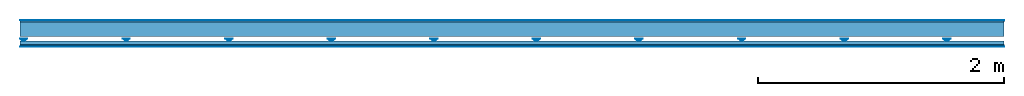
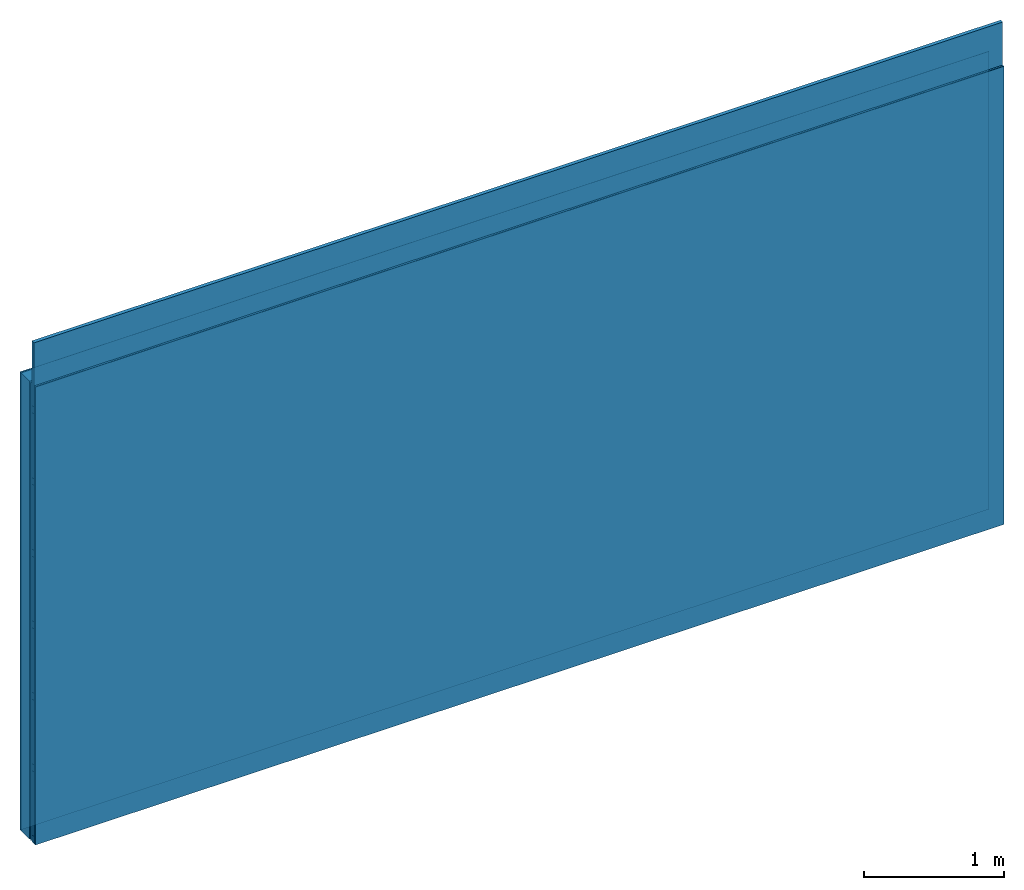
# One storey: 4 members, 4 plates, 1 element without a shape of its own.
"""IFC4 building model written with IfcOpenShell, lengths in metres."""

from ifc_helpers import new_model, si_unit, derived_unit, direction, frame, frame_2d, origin, origin_with_axes, place, context, project, spatial, polyline, rectangle, outline, extrude, material, layer, layer_set, type_object, element, aggregate, save


model = new_model("IFC4")

# Units and contexts
plan_context = context("Plan", 3, precision=1e-05, world=origin(), true_north=direction((0.0, 1.0)))
model_context = context("Model", 3, precision=1e-05, world=origin(), true_north=direction((0.0, 1.0)))
ifc_project = project(units=[si_unit("LENGTHUNIT", "METRE"), derived_unit("SOUNDPRESSUREUNIT", [(si_unit("PRESSUREUNIT", "PASCAL", prefix="MICRO"), 0)]), si_unit("ENERGYUNIT", "JOULE", prefix="MEGA"), si_unit("MASSUNIT", "GRAM", prefix="KILO"), derived_unit("THERMALTRANSMITTANCEUNIT", [(si_unit("POWERUNIT", "WATT"), 1), (si_unit("AREAUNIT", "SQUARE_METRE"), -1), (si_unit("THERMODYNAMICTEMPERATUREUNIT", "KELVIN"), -1)]), derived_unit("AREADENSITYUNIT", [(si_unit("MASSUNIT", "GRAM", prefix="KILO"), 1), (si_unit("AREAUNIT", "SQUARE_METRE"), -1)]), derived_unit("USERDEFINED", [(si_unit("ENERGYUNIT", "JOULE", prefix="MEGA"), 1), (si_unit("AREAUNIT", "SQUARE_METRE"), -1)])], contexts=[plan_context, model_context])

# Site, building, storey
site = spatial("IfcSite", under=ifc_project)
building_placement = place(None, origin())
building = spatial("IfcBuilding", under=site, at=building_placement)
storey_placement = place(building_placement, origin())
storey = spatial("IfcBuildingStorey", under=building, at=storey_placement)

# Wall, members, plates
ifc_material_1 = material(Category="04.001")
ifc_layer_1 = layer(ifc_material_1, 0.003, Name="Surface")
ifc_material_2 = material(Name="Plasterboard type A", Category="03.008")
ifc_layer_2 = layer(ifc_material_2, 0.0125, Name="1st layer")
ifc_material_3 = material(Name="of the art")
ifc_layer_3 = layer(ifc_material_3, 0.0, Name="Bond")
ifc_layer_4 = layer(None, 0.12, Name="Support")
ifc_layer_5 = layer(None, 0.036, Name="Coupling")
ifc_layer_6 = layer(None, 0.03, Name="Battens / profiles")
ifc_material_4 = material(Name="DFH2IR Knauf Diamant hard- plasterboard", Category="03.007")
ifc_layer_7 = layer(ifc_material_4, 0.015, Name="Covering 1st layer")
ifc_layer_8 = layer(ifc_material_1, 0.003, Name="Surface")
ifc_layer_set = layer_set([ifc_layer_1, ifc_layer_2, ifc_layer_3, ifc_layer_4, ifc_layer_5, ifc_layer_6, ifc_layer_7, ifc_layer_8])
wall_type = type_object("IfcWallType", Name="C0377", PredefinedType="NOTDEFINED", material=ifc_layer_set)
wall_placement = place(None, frame((0.0, 0.0, 0.0), z_axis=(0.0, -1.0, 0.0), x_axis=(1.0, 0.0, 0.0)))
wall = element("IfcWall", 1, at=wall_placement, inside=storey, type_object=wall_type, material=ifc_layer_set, Name="Wall #1")
ifc_material_5 = material(Name="Solid timber panel")
member_1_placement = place(wall_placement, origin())
member_1 = element("IfcMember", 2, at=member_1_placement, material=ifc_material_5, Name="Support", context=plan_context, shape_type="SweptSolid", body=[
    extrude(rectangle(XDim=1.0, YDim=0.12, at=frame_2d((0.5, 0.06), x_axis=(1.0, 0.0))), frame((0.0, 4.0, 0.0155), z_axis=(0.0, -1.0, 0.0), x_axis=(1.0, 0.0, 0.0)), (0.0, 0.0, 1.0), 4.0),
    extrude(rectangle(XDim=1.0, YDim=0.12, at=frame_2d((0.5, 0.06), x_axis=(1.0, 0.0))), frame((1.0, 4.0, 0.0155), z_axis=(0.0, -1.0, 0.0), x_axis=(1.0, 0.0, 0.0)), (0.0, 0.0, 1.0), 4.0),
    extrude(rectangle(XDim=1.0, YDim=0.12, at=frame_2d((0.5, 0.06), x_axis=(1.0, 0.0))), frame((2.0, 4.0, 0.0155), z_axis=(0.0, -1.0, 0.0), x_axis=(1.0, 0.0, 0.0)), (0.0, 0.0, 1.0), 4.0),
    extrude(rectangle(XDim=1.0, YDim=0.12, at=frame_2d((0.5, 0.06), x_axis=(1.0, 0.0))), frame((3.0, 4.0, 0.0155), z_axis=(0.0, -1.0, 0.0), x_axis=(1.0, 0.0, 0.0)), (0.0, 0.0, 1.0), 4.0),
    extrude(rectangle(XDim=1.0, YDim=0.12, at=frame_2d((0.5, 0.06), x_axis=(1.0, 0.0))), frame((4.0, 4.0, 0.0155), z_axis=(0.0, -1.0, 0.0), x_axis=(1.0, 0.0, 0.0)), (0.0, 0.0, 1.0), 4.0),
    extrude(rectangle(XDim=1.0, YDim=0.12, at=frame_2d((0.5, 0.06), x_axis=(1.0, 0.0))), frame((5.0, 4.0, 0.0155), z_axis=(0.0, -1.0, 0.0), x_axis=(1.0, 0.0, 0.0)), (0.0, 0.0, 1.0), 4.0),
    extrude(rectangle(XDim=1.0, YDim=0.12, at=frame_2d((0.5, 0.06), x_axis=(1.0, 0.0))), frame((6.0, 4.0, 0.0155), z_axis=(0.0, -1.0, 0.0), x_axis=(1.0, 0.0, 0.0)), (0.0, 0.0, 1.0), 4.0),
    extrude(rectangle(XDim=1.0, YDim=0.12, at=frame_2d((0.5, 0.06), x_axis=(1.0, 0.0))), frame((7.0, 4.0, 0.0155), z_axis=(0.0, -1.0, 0.0), x_axis=(1.0, 0.0, 0.0)), (0.0, 0.0, 1.0), 4.0),
])
ifc_material_6 = material()
member_2_placement = place(wall_placement, origin())
member_2 = element("IfcMember", 3, at=member_2_placement, material=ifc_material_6, Name="Coupling", context=plan_context, shape_type="SweptSolid", body=[
    extrude(outline(polyline([(0.0, 0.0), (0.06, 0.0), (0.04, 0.02), (0.02, 0.02), (0.0, 0.0)])), frame((0.0, 4.0, 0.1515), z_axis=(0.0, -1.0, 0.0), x_axis=(1.0, 0.0, 0.0)), (0.0, 0.0, 1.0), 4.0),
    extrude(outline(polyline([(0.0, 0.0), (0.06, 0.0), (0.04, 0.02), (0.02, 0.02), (0.0, 0.0)])), frame((0.834, 4.0, 0.1515), z_axis=(0.0, -1.0, 0.0), x_axis=(1.0, 0.0, 0.0)), (0.0, 0.0, 1.0), 4.0),
    extrude(outline(polyline([(0.0, 0.0), (0.06, 0.0), (0.04, 0.02), (0.02, 0.02), (0.0, 0.0)])), frame((1.668, 4.0, 0.1515), z_axis=(0.0, -1.0, 0.0), x_axis=(1.0, 0.0, 0.0)), (0.0, 0.0, 1.0), 4.0),
    extrude(outline(polyline([(0.0, 0.0), (0.06, 0.0), (0.04, 0.02), (0.02, 0.02), (0.0, 0.0)])), frame((2.502, 4.0, 0.1515), z_axis=(0.0, -1.0, 0.0), x_axis=(1.0, 0.0, 0.0)), (0.0, 0.0, 1.0), 4.0),
    extrude(outline(polyline([(0.0, 0.0), (0.06, 0.0), (0.04, 0.02), (0.02, 0.02), (0.0, 0.0)])), frame((3.336, 4.0, 0.1515), z_axis=(0.0, -1.0, 0.0), x_axis=(1.0, 0.0, 0.0)), (0.0, 0.0, 1.0), 4.0),
    extrude(outline(polyline([(0.0, 0.0), (0.06, 0.0), (0.04, 0.02), (0.02, 0.02), (0.0, 0.0)])), frame((4.17, 4.0, 0.1515), z_axis=(0.0, -1.0, 0.0), x_axis=(1.0, 0.0, 0.0)), (0.0, 0.0, 1.0), 4.0),
    extrude(outline(polyline([(0.0, 0.0), (0.06, 0.0), (0.04, 0.02), (0.02, 0.02), (0.0, 0.0)])), frame((5.004, 4.0, 0.1515), z_axis=(0.0, -1.0, 0.0), x_axis=(1.0, 0.0, 0.0)), (0.0, 0.0, 1.0), 4.0),
    extrude(outline(polyline([(0.0, 0.0), (0.06, 0.0), (0.04, 0.02), (0.02, 0.02), (0.0, 0.0)])), frame((5.838, 4.0, 0.1515), z_axis=(0.0, -1.0, 0.0), x_axis=(1.0, 0.0, 0.0)), (0.0, 0.0, 1.0), 4.0),
    extrude(outline(polyline([(0.0, 0.0), (0.06, 0.0), (0.04, 0.02), (0.02, 0.02), (0.0, 0.0)])), frame((6.672, 4.0, 0.1515), z_axis=(0.0, -1.0, 0.0), x_axis=(1.0, 0.0, 0.0)), (0.0, 0.0, 1.0), 4.0),
    extrude(outline(polyline([(0.0, 0.0), (0.06, 0.0), (0.04, 0.02), (0.02, 0.02), (0.0, 0.0)])), frame((7.506, 4.0, 0.1515), z_axis=(0.0, -1.0, 0.0), x_axis=(1.0, 0.0, 0.0)), (0.0, 0.0, 1.0), 4.0),
])
member_3_placement = place(wall_placement, origin())
member_3 = element("IfcMember", 4, at=member_3_placement, material=ifc_material_6, Name="Battens / profiles", context=plan_context, shape_type="SweptSolid", body=[
    extrude(rectangle(XDim=0.06, YDim=0.03, at=frame_2d((0.03, 0.015), x_axis=(1.0, 0.0))), frame((0.0, 0.0, 0.1715), z_axis=(1.0, 0.0, 0.0), x_axis=(0.0, 1.0, 0.0)), (0.0, 0.0, 1.0), 8.0),
    extrude(rectangle(XDim=0.06, YDim=0.03, at=frame_2d((0.03, 0.015), x_axis=(1.0, 0.0))), frame((0.0, 0.625, 0.1715), z_axis=(1.0, 0.0, 0.0), x_axis=(0.0, 1.0, 0.0)), (0.0, 0.0, 1.0), 8.0),
    extrude(rectangle(XDim=0.06, YDim=0.03, at=frame_2d((0.03, 0.015), x_axis=(1.0, 0.0))), frame((0.0, 1.25, 0.1715), z_axis=(1.0, 0.0, 0.0), x_axis=(0.0, 1.0, 0.0)), (0.0, 0.0, 1.0), 8.0),
    extrude(rectangle(XDim=0.06, YDim=0.03, at=frame_2d((0.03, 0.015), x_axis=(1.0, 0.0))), frame((0.0, 1.875, 0.1715), z_axis=(1.0, 0.0, 0.0), x_axis=(0.0, 1.0, 0.0)), (0.0, 0.0, 1.0), 8.0),
    extrude(rectangle(XDim=0.06, YDim=0.03, at=frame_2d((0.03, 0.015), x_axis=(1.0, 0.0))), frame((0.0, 2.5, 0.1715), z_axis=(1.0, 0.0, 0.0), x_axis=(0.0, 1.0, 0.0)), (0.0, 0.0, 1.0), 8.0),
    extrude(rectangle(XDim=0.06, YDim=0.03, at=frame_2d((0.03, 0.015), x_axis=(1.0, 0.0))), frame((0.0, 3.125, 0.1715), z_axis=(1.0, 0.0, 0.0), x_axis=(0.0, 1.0, 0.0)), (0.0, 0.0, 1.0), 8.0),
    extrude(rectangle(XDim=0.06, YDim=0.03, at=frame_2d((0.03, 0.015), x_axis=(1.0, 0.0))), frame((0.0, 3.75, 0.1715), z_axis=(1.0, 0.0, 0.0), x_axis=(0.0, 1.0, 0.0)), (0.0, 0.0, 1.0), 8.0),
])
ifc_material_7 = material()
member_4_placement = place(wall_placement, origin())
member_4 = element("IfcMember", 5, at=member_4_placement, material=ifc_material_7, Name="Cavity", context=plan_context, shape_type="SweptSolid", body=[
    extrude(rectangle(XDim=0.565, YDim=0.03, at=frame_2d((0.2825, 0.015), x_axis=(1.0, 0.0))), frame((0.0, 0.06, 0.1715), z_axis=(1.0, 0.0, 0.0), x_axis=(0.0, 1.0, 0.0)), (0.0, 0.0, 1.0), 8.0),
    extrude(rectangle(XDim=0.565, YDim=0.03, at=frame_2d((0.2825, 0.015), x_axis=(1.0, 0.0))), frame((0.0, 0.685, 0.1715), z_axis=(1.0, 0.0, 0.0), x_axis=(0.0, 1.0, 0.0)), (0.0, 0.0, 1.0), 8.0),
    extrude(rectangle(XDim=0.565, YDim=0.03, at=frame_2d((0.2825, 0.015), x_axis=(1.0, 0.0))), frame((0.0, 1.31, 0.1715), z_axis=(1.0, 0.0, 0.0), x_axis=(0.0, 1.0, 0.0)), (0.0, 0.0, 1.0), 8.0),
    extrude(rectangle(XDim=0.565, YDim=0.03, at=frame_2d((0.2825, 0.015), x_axis=(1.0, 0.0))), frame((0.0, 1.935, 0.1715), z_axis=(1.0, 0.0, 0.0), x_axis=(0.0, 1.0, 0.0)), (0.0, 0.0, 1.0), 8.0),
    extrude(rectangle(XDim=0.565, YDim=0.03, at=frame_2d((0.2825, 0.015), x_axis=(1.0, 0.0))), frame((0.0, 2.56, 0.1715), z_axis=(1.0, 0.0, 0.0), x_axis=(0.0, 1.0, 0.0)), (0.0, 0.0, 1.0), 8.0),
    extrude(rectangle(XDim=0.565, YDim=0.03, at=frame_2d((0.2825, 0.015), x_axis=(1.0, 0.0))), frame((0.0, 3.185, 0.1715), z_axis=(1.0, 0.0, 0.0), x_axis=(0.0, 1.0, 0.0)), (0.0, 0.0, 1.0), 8.0),
    extrude(rectangle(XDim=0.565, YDim=0.03, at=frame_2d((0.2825, 0.015), x_axis=(1.0, 0.0))), frame((0.0, 3.81, 0.1715), z_axis=(1.0, 0.0, 0.0), x_axis=(0.0, 1.0, 0.0)), (0.0, 0.0, 1.0), 8.0),
])
plate_1_placement = place(wall_placement, origin())
plate_1 = element("IfcPlate", 6, at=plate_1_placement, material=ifc_material_1, Name="Surface", context=plan_context, shape_type="SweptSolid", body=[
    extrude(rectangle(XDim=8.0, YDim=4.0, at=frame_2d((4.0, 2.0), x_axis=(1.0, 0.0))), origin_with_axes(), (0.0, 0.0, 1.0), 0.003),
])
plate_2_placement = place(wall_placement, origin())
plate_2 = element("IfcPlate", 7, at=plate_2_placement, material=ifc_material_2, Name="1st layer", context=plan_context, shape_type="SweptSolid", body=[
    extrude(rectangle(XDim=8.0, YDim=4.0, at=frame_2d((4.0, 2.0), x_axis=(1.0, 0.0))), frame((0.0, 0.0, 0.003), z_axis=(0.0, 0.0, 1.0), x_axis=(1.0, 0.0, 0.0)), (0.0, 0.0, 1.0), 0.0125),
])
plate_3_placement = place(wall_placement, origin())
plate_3 = element("IfcPlate", 8, at=plate_3_placement, material=ifc_material_4, Name="Covering 1st layer", context=plan_context, shape_type="SweptSolid", body=[
    extrude(rectangle(XDim=8.0, YDim=4.0, at=frame_2d((4.0, 2.0), x_axis=(1.0, 0.0))), frame((0.0, 0.0, 0.2015), z_axis=(0.0, 0.0, 1.0), x_axis=(1.0, 0.0, 0.0)), (0.0, 0.0, 1.0), 0.015),
])
plate_4_placement = place(wall_placement, origin())
plate_4 = element("IfcPlate", 9, at=plate_4_placement, material=ifc_material_1, Name="Surface", context=plan_context, shape_type="SweptSolid", body=[
    extrude(rectangle(XDim=8.0, YDim=4.0, at=frame_2d((4.0, 2.0), x_axis=(1.0, 0.0))), frame((0.0, 0.0, 0.2165), z_axis=(0.0, 0.0, 1.0), x_axis=(1.0, 0.0, 0.0)), (0.0, 0.0, 1.0), 0.003),
])
aggregate(wall, [plate_1, plate_2, member_1, member_2, member_3, member_4, plate_3, plate_4])

save(model, "model.ifc")
